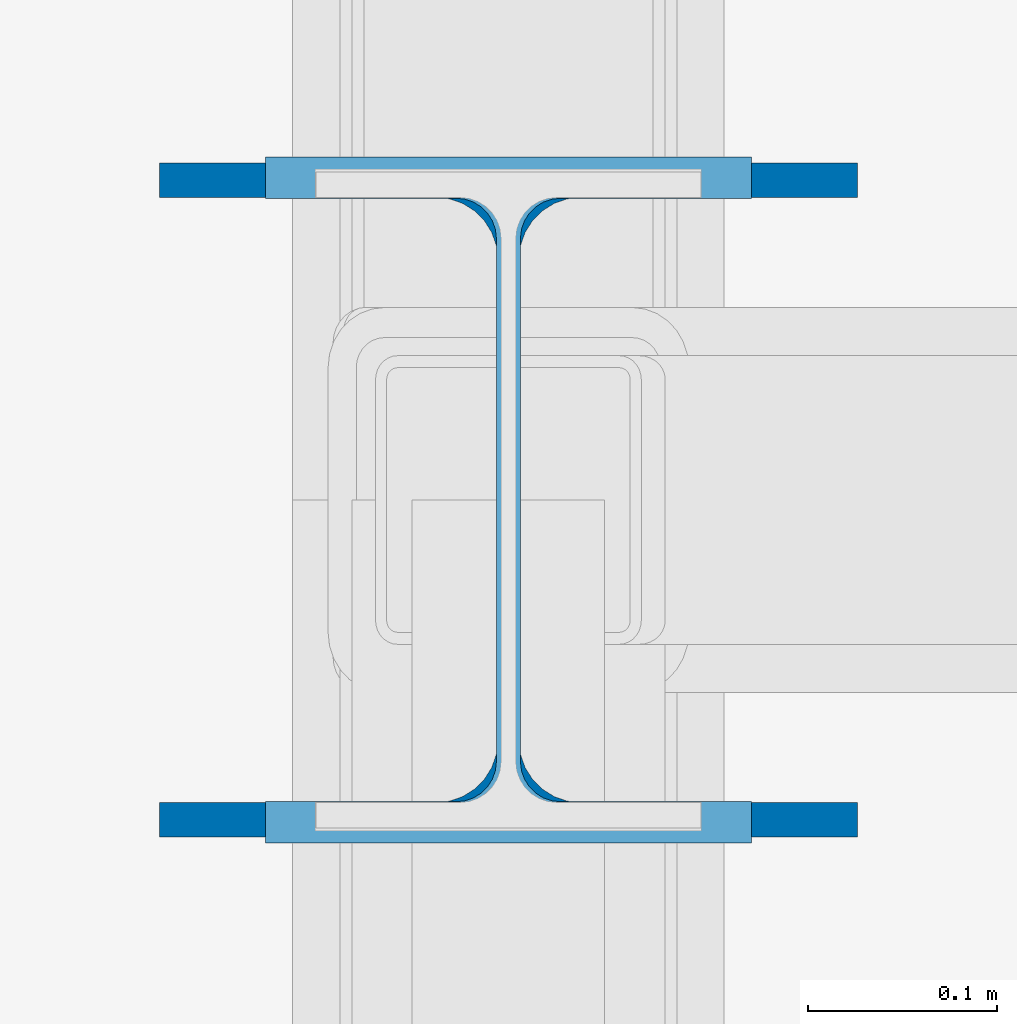
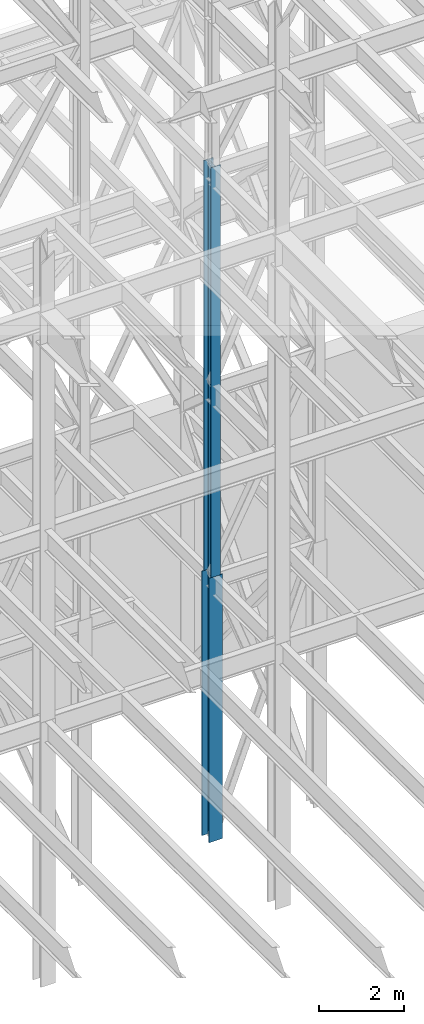
# One storey, part 93 of 150: 2 columns.
"""IFC2X3 building model written with IfcOpenShell, lengths in millimetres."""

from ifc_helpers import new_model, si_unit, frame, origin_with_axes, origin_2d_with_axis, place, context, subcontext, project, spatial, i_section, extrude, material, type_object, element, save


model = new_model("IFC2X3")

# Units and contexts
model_context = context("Model", 3, precision=1e-05, world=origin_with_axes())
body_context = subcontext(model_context, "Body", "Model", "MODEL_VIEW")
ifc_project = project(units=[si_unit("LENGTHUNIT", "METRE", prefix="MILLI"), si_unit("AREAUNIT", "SQUARE_METRE"), si_unit("VOLUMEUNIT", "CUBIC_METRE"), si_unit("MASSUNIT", "GRAM", prefix="KILO"), si_unit("TIMEUNIT", "SECOND"), si_unit("PLANEANGLEUNIT", "RADIAN"), si_unit("SOLIDANGLEUNIT", "STERADIAN"), si_unit("THERMODYNAMICTEMPERATUREUNIT", "DEGREE_CELSIUS"), si_unit("LUMINOUSINTENSITYUNIT", "LUMEN")], contexts=[model_context])

# Site, building, storey
site_placement = place(None, origin_with_axes())
site = spatial("IfcSite", under=ifc_project, at=site_placement, CompositionType="ELEMENT")
building_placement = place(site_placement, origin_with_axes())
building = spatial("IfcBuilding", under=site, at=building_placement, Name="Undefined", CompositionType="ELEMENT")
storey_placement = place(building_placement, origin_with_axes())
storey = spatial("IfcBuildingStorey", under=building, at=storey_placement, Name="Undefined", CompositionType="ELEMENT", Elevation=0.0)

# Columns
ifc_material = material(Name="STEEL/A992")
column_type_1 = type_object("IfcColumnType", Name="W14X90", PredefinedType="NOTDEFINED")
column_1_placement = place(storey_placement, frame((62992.0, 25628.6, 16154.401143), z_axis=(0.0, 0.0, 1.0), x_axis=(1.0, 0.0, 0.0)))
element("IfcColumn", 1, at=column_1_placement, inside=storey, type_object=column_type_1, material=ifc_material, Name="COLUMN", ObjectType="W14X90", context=body_context, shape_type="SweptSolid", body=[
    extrude(i_section(OverallWidth=368.3, OverallDepth=355.6, WebThickness=11.1125, FlangeThickness=18.034, FilletRadius=32.7659, at=origin_2d_with_axis()), frame((0.0, 0.0, 7620.0), z_axis=(0.0, 0.0, -1.0), x_axis=(-1.0, 0.0, 0.0)), (0.0, 0.0, 1.0), 7620.0),
])
column_type_2 = type_object("IfcColumnType", Name="W14X82", PredefinedType="NOTDEFINED")
column_2_placement = place(storey_placement, frame((62992.0, 25628.6, 23774.401143), z_axis=(0.0, 0.0, 1.0), x_axis=(1.0, 0.0, 0.0)))
element("IfcColumn", 2, at=column_2_placement, inside=storey, type_object=column_type_2, material=ifc_material, Name="COLUMN", ObjectType="W14X82", context=body_context, shape_type="SweptSolid", body=[
    extrude(i_section(OverallWidth=256.54, OverallDepth=361.95, WebThickness=12.6999, FlangeThickness=21.717, FilletRadius=21.1455, at=origin_2d_with_axis()), frame((0.0, 0.0, 11811.0), z_axis=(0.0, 0.0, -1.0), x_axis=(-1.0, 0.0, 0.0)), (0.0, 0.0, 1.0), 11811.0),
])

save(model, "model.ifc")
